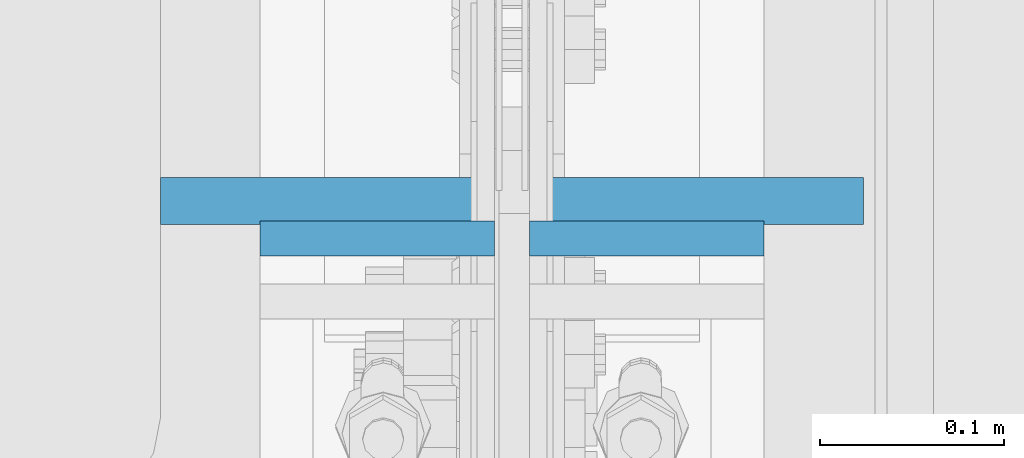
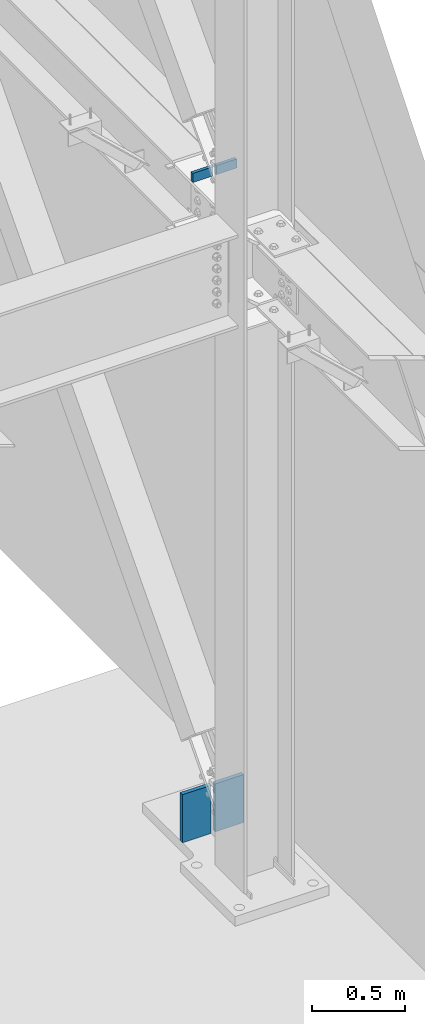
# One storey, part 468 of 1179: 4 columns, 3 elements without a shape of their own.
"""IFC2X3 building model written with IfcOpenShell, lengths in millimetres."""

from ifc_helpers import new_model, si_unit, frame, origin_with_axes, place, context, subcontext, project, spatial, faceted_brep, material, type_object, element, aggregate, save


model = new_model("IFC2X3")

# Units and contexts
model_context = context("Model", 3, precision=1e-05, world=origin_with_axes())
body_context = subcontext(model_context, "Body", "Model", "MODEL_VIEW")
ifc_project = project(units=[si_unit("LENGTHUNIT", "METRE", prefix="MILLI"), si_unit("AREAUNIT", "SQUARE_METRE"), si_unit("VOLUMEUNIT", "CUBIC_METRE"), si_unit("MASSUNIT", "GRAM", prefix="KILO"), si_unit("TIMEUNIT", "SECOND"), si_unit("PLANEANGLEUNIT", "RADIAN"), si_unit("SOLIDANGLEUNIT", "STERADIAN"), si_unit("THERMODYNAMICTEMPERATUREUNIT", "DEGREE_CELSIUS"), si_unit("LUMINOUSINTENSITYUNIT", "LUMEN")], contexts=[model_context])

# Site, building, storey
site_placement = place(None, origin_with_axes())
site = spatial("IfcSite", under=ifc_project, at=site_placement, CompositionType="ELEMENT")
building_placement = place(site_placement, origin_with_axes())
building = spatial("IfcBuilding", under=site, at=building_placement, Name="Undefined", CompositionType="ELEMENT")
storey_placement = place(building_placement, origin_with_axes())
storey = spatial("IfcBuildingStorey", under=building, at=storey_placement, Name="Undefined", CompositionType="ELEMENT", Elevation=0.0)

# Assembly, column
assembly_1_placement = place(storey_placement, origin_with_axes())
assembly_1 = element("IfcElementAssembly", 1, at=assembly_1_placement, inside=storey, Name="PLATE", AssemblyPlace="NOTDEFINED", PredefinedType="RIGID_FRAME")
ifc_material = material(Name="STEEL/A572-GR.50")
column_type_1 = type_object("IfcColumnType", PredefinedType="NOTDEFINED")
column_1_placement = place(assembly_1_placement, frame((24206.2, 27511.3198388933, -215.9), z_axis=(1.0, 0.0, 0.0), x_axis=(0.0, 0.0, 1.0)))
column_1 = element("IfcColumn", 2, at=column_1_placement, type_object=column_type_1, material=ifc_material, Name="PLATE", context=body_context, shape_type="Brep", body=[
    faceted_brep([(0.0, 12.6999999999998, -88.9000000000015), (0.0, 12.6999999999998, 88.9000000000015), (314.840055491836, 12.7000000000007, 88.9000000000015), (314.840055491836, 12.7000000000007, -88.9000000000015), (0.0, -12.6999999999998, 88.9000000000015), (314.840055491836, -12.7000000000007, 88.9000000000015), (0.0, -12.6999999999998, -88.9000000000015), (314.840055491836, -12.7000000000007, -88.9000000000015)], [[[0, 1, 2, 3]], [[1, 4, 5, 2]], [[4, 6, 7, 5]], [[6, 0, 3, 7]], [[5, 7, 3, 2]], [[6, 4, 1, 0]]]),
])
aggregate(assembly_1, [column_1])

assembly_2_placement = place(storey_placement, origin_with_axes())
assembly_2 = element("IfcElementAssembly", 3, at=assembly_2_placement, inside=storey, Name="PLATE", AssemblyPlace="NOTDEFINED", PredefinedType="RIGID_FRAME")
column_2_placement = place(assembly_2_placement, frame((24409.4, 27511.3198388933, -215.9), z_axis=(-1.0, 0.0, 0.0), x_axis=(0.0, 0.0, 1.0)))
column_2 = element("IfcColumn", 4, at=column_2_placement, type_object=column_type_1, material=ifc_material, Name="PLATE", context=body_context, shape_type="Brep", body=[
    faceted_brep([(0.0, 12.6999999999998, -88.9000000000015), (0.0, 12.6999999999998, 88.9000000000015), (314.840055491836, 12.7000000000007, 88.9000000000015), (314.840055491836, 12.7000000000007, -88.9000000000015), (0.0, -12.6999999999998, 88.9000000000015), (314.840055491836, -12.7000000000007, 88.9000000000015), (0.0, -12.6999999999998, -88.9000000000015), (314.840055491836, -12.7000000000007, -88.9000000000015)], [[[0, 1, 2, 3]], [[1, 4, 5, 2]], [[4, 6, 7, 5]], [[6, 0, 3, 7]], [[5, 7, 3, 2]], [[6, 4, 1, 0]]]),
])
aggregate(assembly_2, [column_2])

# Assembly, columns
assembly_3_placement = place(storey_placement, origin_with_axes())
assembly_3 = element("IfcElementAssembly", 5, at=assembly_3_placement, inside=storey, Name="COLUMN", AssemblyPlace="NOTDEFINED", PredefinedType="RIGID_FRAME")
column_type_2 = type_object("IfcColumnType", PredefinedType="NOTDEFINED")
column_3_placement = place(assembly_3_placement, frame((24234.775, 27490.958001131, 4102.1), z_axis=(1.0, 0.0, 0.0), x_axis=(0.0, 0.0, 1.0)))
column_3 = element("IfcColumn", 6, at=column_3_placement, type_object=column_type_2, material=ifc_material, Name="PLATE", context=body_context, shape_type="Brep", body=[
    faceted_brep([(0.0, 9.52500000000146, -63.5), (0.0, 9.52500000000146, 63.5), (59.8857973215509, 9.52500000000146, 63.5), (59.8857973215509, 9.52500000000146, -63.5), (0.0, -9.52500000000146, 63.5), (59.8857973215509, -9.52500000000146, 63.5), (0.0, -9.52500000000146, -63.5), (59.8857973215509, -9.52500000000146, -63.5)], [[[0, 1, 2, 3]], [[1, 4, 5, 2]], [[4, 6, 7, 5]], [[6, 0, 3, 7]], [[5, 7, 3, 2]], [[6, 4, 1, 0]]]),
])
column_4_placement = place(assembly_3_placement, frame((24380.825, 27490.958001131, 4102.1), z_axis=(-1.0, 0.0, 0.0), x_axis=(0.0, 0.0, 1.0)))
column_4 = element("IfcColumn", 7, at=column_4_placement, type_object=column_type_2, material=ifc_material, Name="PLATE", context=body_context, shape_type="Brep", body=[
    faceted_brep([(0.0, 9.52500000000146, -63.5), (0.0, 9.52500000000146, 63.5), (59.8857973215509, 9.52500000000146, 63.5), (59.8857973215509, 9.52500000000146, -63.5), (0.0, -9.52500000000146, 63.5), (59.8857973215509, -9.52500000000146, 63.5), (0.0, -9.52500000000146, -63.5), (59.8857973215509, -9.52500000000146, -63.5)], [[[0, 1, 2, 3]], [[1, 4, 5, 2]], [[4, 6, 7, 5]], [[6, 0, 3, 7]], [[5, 7, 3, 2]], [[6, 4, 1, 0]]]),
])
aggregate(assembly_3, [column_3, column_4])

save(model, "model.ifc")
